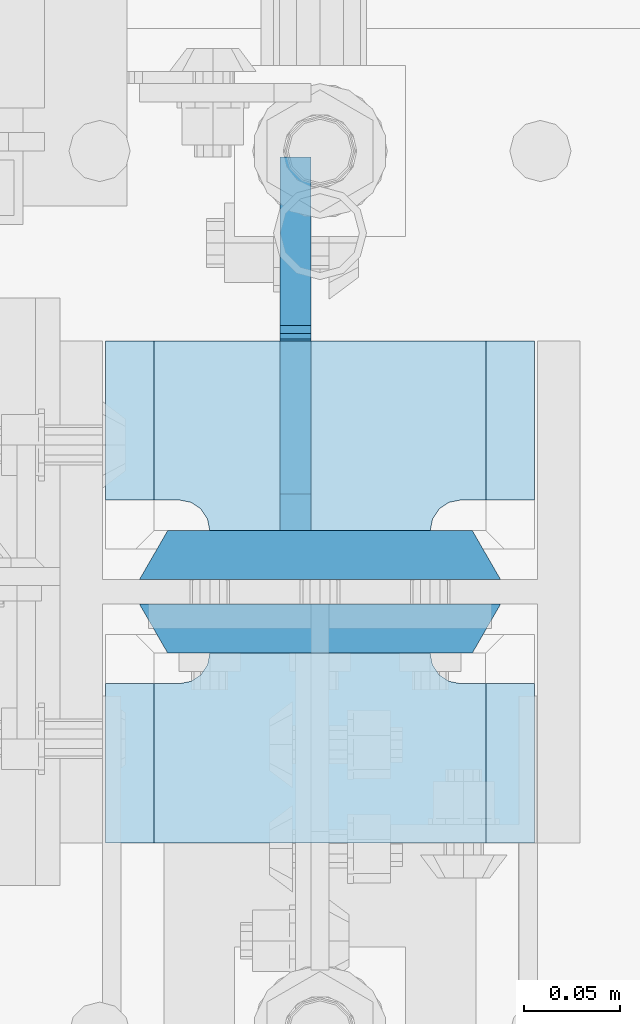
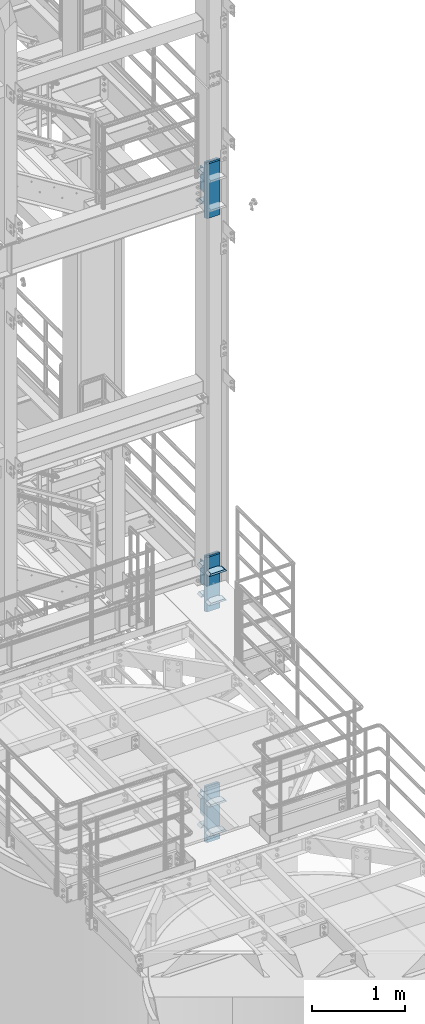
# One storey, part 1521 of 1876: 19 plates, 1 element without a shape of its own.
"""IFC2X3 building model written with IfcOpenShell, lengths in millimetres."""

from ifc_helpers import new_model, si_unit, frame, origin_with_axes, place, context, subcontext, project, spatial, faceted_brep, material, type_object, element, aggregate, save


model = new_model("IFC2X3")

# Units and contexts
model_context = context("Model", 3, precision=1e-05, world=origin_with_axes())
body_context = subcontext(model_context, "Body", "Model", "MODEL_VIEW")
ifc_project = project(units=[si_unit("LENGTHUNIT", "METRE", prefix="MILLI"), si_unit("AREAUNIT", "SQUARE_METRE"), si_unit("VOLUMEUNIT", "CUBIC_METRE"), si_unit("MASSUNIT", "GRAM", prefix="KILO"), si_unit("TIMEUNIT", "SECOND"), si_unit("PLANEANGLEUNIT", "RADIAN"), si_unit("SOLIDANGLEUNIT", "STERADIAN"), si_unit("THERMODYNAMICTEMPERATUREUNIT", "DEGREE_CELSIUS"), si_unit("LUMINOUSINTENSITYUNIT", "LUMEN")], contexts=[model_context])

# Site, building, storey
site_placement = place(None, origin_with_axes())
site = spatial("IfcSite", under=ifc_project, at=site_placement, CompositionType="ELEMENT")
building_placement = place(site_placement, origin_with_axes())
building = spatial("IfcBuilding", under=site, at=building_placement, Name="Undefined", CompositionType="ELEMENT")
storey_placement = place(building_placement, origin_with_axes())
storey = spatial("IfcBuildingStorey", under=building, at=storey_placement, Name="Undefined", CompositionType="ELEMENT", Elevation=0.0)

# Assembly, plates
assembly_placement = place(storey_placement, origin_with_axes())
assembly = element("IfcElementAssembly", 1, at=assembly_placement, inside=storey, Name="COLUMN", AssemblyPlace="NOTDEFINED", PredefinedType="RIGID_FRAME")
ifc_material_1 = material(Name="STEEL/A572-GR.50")
plate_type_1 = type_object("IfcPlateType", PredefinedType="NOTDEFINED")
plate_1_placement = place(assembly_placement, frame((7731.125, -6981.825, 12912.725012207), z_axis=(-1.0, 0.0, 0.0), x_axis=(0.0, -1.0, 0.0)))
plate_1 = element("IfcPlate", 2, at=plate_1_placement, type_object=plate_type_1, material=ifc_material_1, Name="PLATE", context=body_context, shape_type="Brep", body=[
    faceted_brep([(82.5500030517578, -12.7000000000007, 222.25), (82.5500030517578, 12.7000000000007, 197.150000002177), (0.0, 12.7000000000007, 197.150000002177), (0.0, -12.7000000000007, 222.25), (82.5500030517578, 12.7000000000007, 25.0999999978233), (82.5500030517578, -12.7000000000007, 0.0), (0.0, -12.6999999999998, 0.0), (0.0, 12.7000000000007, 25.0999999978233), (82.5500030517578, 12.7000000000007, 38.0999984741211), (82.5500030517578, -12.7000000000007, 38.0999984741211), (83.7584154731412, -12.7000000000007, 44.1750979629169), (83.7584154731412, 12.7000000000007, 44.1750979629169), (87.1996829004211, -12.7000000000007, 49.3253186254576), (87.1996829004211, 12.7000000000007, 49.3253186254576), (92.349903562962, -12.7000000000007, 52.7665860527377), (92.349903562962, 12.7000000000007, 52.7665860527377), (98.4250030517578, -12.7000000000007, 53.9749984741211), (98.4250030517578, 12.7000000000007, 53.9749984741211), (98.4250030517578, -12.7000000000007, 168.275001525879), (98.4250030517578, 12.7000000000007, 168.275001525879), (92.349903562962, -12.7000000000007, 169.483413947262), (92.349903562962, 12.7000000000007, 169.483413947262), (87.1996829004211, -12.7000000000007, 172.924681374543), (87.1996829004211, 12.7000000000007, 172.924681374543), (83.7584154731412, -12.7000000000007, 178.074902037083), (83.7584154731412, 12.7000000000007, 178.074902037083), (82.5500030517578, -12.7000000000007, 184.150001525879), (82.5500030517578, 12.7000000000007, 184.150001525879)], [[[0, 1, 2, 3]], [[4, 5, 6, 7]], [[8, 9, 5, 4]], [[10, 9, 8, 11]], [[12, 10, 11, 13]], [[14, 12, 13, 15]], [[16, 14, 15, 17]], [[18, 16, 17, 19]], [[20, 18, 19, 21]], [[22, 20, 21, 23]], [[24, 22, 23, 25]], [[26, 24, 25, 27]], [[6, 5, 9, 10, 12, 14, 16, 18, 20, 22, 24, 26, 0, 3]], [[7, 6, 3, 2]], [[27, 25, 23, 21, 19, 17, 15, 13, 11, 8, 4, 7, 2, 1]], [[26, 27, 1, 0]]]),
])
plate_2_placement = place(assembly_placement, frame((7731.125, -6981.825, 13296.9), z_axis=(-1.0, 0.0, 0.0), x_axis=(0.0, -1.0, 0.0)))
plate_2 = element("IfcPlate", 3, at=plate_2_placement, type_object=plate_type_1, material=ifc_material_1, Name="PLATE", context=body_context, shape_type="Brep", body=[
    faceted_brep([(82.5500030517578, -12.7000000000007, 222.25), (82.5500030517578, 12.7000000000007, 197.150000002177), (0.0, 12.7000000000007, 197.150000002177), (0.0, -12.7000000000007, 222.25), (82.5500030517578, 12.7000000000007, 25.0999999978233), (82.5500030517578, -12.7000000000007, 0.0), (0.0, -12.6999999999998, 0.0), (0.0, 12.7000000000007, 25.0999999978233), (82.5500030517578, 12.7000000000007, 38.0999984741211), (82.5500030517578, -12.7000000000007, 38.0999984741211), (83.7584154731412, -12.7000000000007, 44.1750979629169), (83.7584154731412, 12.7000000000007, 44.1750979629169), (87.1996829004211, -12.7000000000007, 49.3253186254576), (87.1996829004211, 12.7000000000007, 49.3253186254576), (92.349903562962, -12.7000000000007, 52.7665860527377), (92.349903562962, 12.7000000000007, 52.7665860527377), (98.4250030517578, -12.7000000000007, 53.9749984741211), (98.4250030517578, 12.7000000000007, 53.9749984741211), (98.4250030517578, -12.7000000000007, 168.275001525879), (98.4250030517578, 12.7000000000007, 168.275001525879), (92.349903562962, -12.7000000000007, 169.483413947262), (92.349903562962, 12.7000000000007, 169.483413947262), (87.1996829004211, -12.7000000000007, 172.924681374543), (87.1996829004211, 12.7000000000007, 172.924681374543), (83.7584154731412, -12.7000000000007, 178.074902037083), (83.7584154731412, 12.7000000000007, 178.074902037083), (82.5500030517578, -12.7000000000007, 184.150001525879), (82.5500030517578, 12.7000000000007, 184.150001525879)], [[[0, 1, 2, 3]], [[4, 5, 6, 7]], [[8, 9, 5, 4]], [[10, 9, 8, 11]], [[12, 10, 11, 13]], [[14, 12, 13, 15]], [[16, 14, 15, 17]], [[18, 16, 17, 19]], [[20, 18, 19, 21]], [[22, 20, 21, 23]], [[24, 22, 23, 25]], [[26, 24, 25, 27]], [[6, 5, 9, 10, 12, 14, 16, 18, 20, 22, 24, 26, 0, 3]], [[7, 6, 3, 2]], [[27, 25, 23, 21, 19, 17, 15, 13, 11, 8, 4, 7, 2, 1]], [[26, 27, 1, 0]]]),
])
plate_3_placement = place(assembly_placement, frame((7731.125, -7143.75, 7756.52500610352), z_axis=(-1.0, 0.0, 0.0), x_axis=(0.0, -1.0, 0.0)))
plate_3 = element("IfcPlate", 4, at=plate_3_placement, type_object=plate_type_1, material=ifc_material_1, Name="PLATE", context=body_context, shape_type="Brep", body=[
    faceted_brep([(98.4250030517578, -12.7000000000007, 222.25), (98.4250030517578, 12.7000000000007, 197.150000002177), (15.875, 12.7000000000007, 197.150000002177), (15.875, -12.7000000000007, 222.25), (14.6665875786157, -12.7000000000007, 178.074902037082), (15.875, -12.7000000000007, 184.150001525879), (15.875, 12.7000000000007, 184.150001525879), (14.6665875786157, 12.7000000000007, 178.074902037082), (11.2253201513358, -12.7000000000007, 172.924681374541), (11.2253201513358, 12.7000000000007, 172.924681374541), (6.07509948879488, -12.7000000000007, 169.483413947261), (6.07509948879488, 12.7000000000007, 169.483413947261), (0.0, -12.7000000000007, 168.275001525879), (0.0, 12.7000000000007, 168.275001525879), (0.0, -12.7000000000007, 53.9749984741211), (0.0, 12.7000000000007, 53.9749984741211), (6.07509948879579, -12.7000000000007, 52.7665860527377), (6.07509948879579, 12.7000000000007, 52.7665860527377), (11.2253201513367, -12.7000000000007, 49.3253186254576), (11.2253201513367, 12.7000000000007, 49.3253186254576), (14.6665875786166, -12.7000000000007, 44.1750979629169), (14.6665875786166, 12.7000000000007, 44.1750979629169), (15.875, -12.7000000000007, 38.0999984741211), (15.875, 12.7000000000007, 38.0999984741211), (15.875, 12.7000000000007, 25.0999999978233), (15.875, -12.7000000000007, 0.0), (98.4250030517578, 12.7000000000007, 25.0999999978233), (98.4250030517578, -12.7000000000007, 0.0)], [[[0, 1, 2, 3]], [[4, 5, 6, 7]], [[8, 4, 7, 9]], [[10, 8, 9, 11]], [[12, 10, 11, 13]], [[14, 12, 13, 15]], [[16, 14, 15, 17]], [[18, 16, 17, 19]], [[20, 18, 19, 21]], [[22, 20, 21, 23]], [[22, 23, 24, 25]], [[26, 27, 25, 24]], [[5, 4, 8, 10, 12, 14, 16, 18, 20, 22, 25, 27, 0, 3]], [[6, 5, 3, 2]], [[26, 24, 23, 21, 19, 17, 15, 13, 11, 9, 7, 6, 2, 1]], [[27, 26, 1, 0]]]),
])
plate_4_placement = place(assembly_placement, frame((7731.125, -7143.75, 8140.7), z_axis=(-1.0, 0.0, 0.0), x_axis=(0.0, -1.0, 0.0)))
plate_4 = element("IfcPlate", 5, at=plate_4_placement, type_object=plate_type_1, material=ifc_material_1, Name="PLATE", context=body_context, shape_type="Brep", body=[
    faceted_brep([(98.4250030517578, -12.7000000000007, 222.25), (98.4250030517578, 12.7000000000007, 197.150000002177), (15.875, 12.7000000000007, 197.150000002177), (15.875, -12.7000000000007, 222.25), (14.6665875786157, -12.7000000000007, 178.074902037082), (15.875, -12.7000000000007, 184.150001525879), (15.875, 12.7000000000007, 184.150001525879), (14.6665875786157, 12.7000000000007, 178.074902037082), (11.2253201513358, -12.7000000000007, 172.924681374541), (11.2253201513358, 12.7000000000007, 172.924681374541), (6.07509948879488, -12.7000000000007, 169.483413947261), (6.07509948879488, 12.7000000000007, 169.483413947261), (0.0, -12.7000000000007, 168.275001525879), (0.0, 12.7000000000007, 168.275001525879), (0.0, -12.7000000000007, 53.9749984741211), (0.0, 12.7000000000007, 53.9749984741211), (6.07509948879579, -12.7000000000007, 52.7665860527377), (6.07509948879579, 12.7000000000007, 52.7665860527377), (11.2253201513367, -12.7000000000007, 49.3253186254576), (11.2253201513367, 12.7000000000007, 49.3253186254576), (14.6665875786166, -12.7000000000007, 44.1750979629169), (14.6665875786166, 12.7000000000007, 44.1750979629169), (15.875, -12.7000000000007, 38.0999984741211), (15.875, 12.7000000000007, 38.0999984741211), (15.875, 12.7000000000007, 25.0999999978233), (15.875, -12.7000000000007, 0.0), (98.4250030517578, 12.7000000000007, 25.0999999978233), (98.4250030517578, -12.7000000000007, 0.0)], [[[0, 1, 2, 3]], [[4, 5, 6, 7]], [[8, 4, 7, 9]], [[10, 8, 9, 11]], [[12, 10, 11, 13]], [[14, 12, 13, 15]], [[16, 14, 15, 17]], [[18, 16, 17, 19]], [[20, 18, 19, 21]], [[22, 20, 21, 23]], [[22, 23, 24, 25]], [[26, 27, 25, 24]], [[5, 4, 8, 10, 12, 14, 16, 18, 20, 22, 25, 27, 0, 3]], [[6, 5, 3, 2]], [[26, 24, 23, 21, 19, 17, 15, 13, 11, 9, 7, 6, 2, 1]], [[27, 26, 1, 0]]]),
])
plate_5_placement = place(assembly_placement, frame((7731.125, -6981.825, 7756.52500610352), z_axis=(-1.0, 0.0, 0.0), x_axis=(0.0, -1.0, 0.0)))
plate_5 = element("IfcPlate", 6, at=plate_5_placement, type_object=plate_type_1, material=ifc_material_1, Name="PLATE", context=body_context, shape_type="Brep", body=[
    faceted_brep([(82.5500030517578, -12.7000000000007, 222.25), (82.5500030517578, 12.7000000000007, 197.150000002177), (0.0, 12.7000000000007, 197.150000002177), (0.0, -12.7000000000007, 222.25), (82.5500030517578, 12.7000000000007, 25.0999999978233), (82.5500030517578, -12.7000000000007, 0.0), (0.0, -12.6999999999998, 0.0), (0.0, 12.7000000000007, 25.0999999978233), (82.5500030517578, 12.7000000000007, 38.0999984741211), (82.5500030517578, -12.7000000000007, 38.0999984741211), (83.7584154731412, -12.7000000000007, 44.1750979629169), (83.7584154731412, 12.7000000000007, 44.1750979629169), (87.1996829004211, -12.7000000000007, 49.3253186254576), (87.1996829004211, 12.7000000000007, 49.3253186254576), (92.349903562962, -12.7000000000007, 52.7665860527377), (92.349903562962, 12.7000000000007, 52.7665860527377), (98.4250030517578, -12.7000000000007, 53.9749984741211), (98.4250030517578, 12.7000000000007, 53.9749984741211), (98.4250030517578, -12.7000000000007, 168.275001525879), (98.4250030517578, 12.7000000000007, 168.275001525879), (92.349903562962, -12.7000000000007, 169.483413947262), (92.349903562962, 12.7000000000007, 169.483413947262), (87.1996829004211, -12.7000000000007, 172.924681374543), (87.1996829004211, 12.7000000000007, 172.924681374543), (83.7584154731412, -12.7000000000007, 178.074902037083), (83.7584154731412, 12.7000000000007, 178.074902037083), (82.5500030517578, -12.7000000000007, 184.150001525879), (82.5500030517578, 12.7000000000007, 184.150001525879)], [[[0, 1, 2, 3]], [[4, 5, 6, 7]], [[8, 9, 5, 4]], [[10, 9, 8, 11]], [[12, 10, 11, 13]], [[14, 12, 13, 15]], [[16, 14, 15, 17]], [[18, 16, 17, 19]], [[20, 18, 19, 21]], [[22, 20, 21, 23]], [[24, 22, 23, 25]], [[26, 24, 25, 27]], [[6, 5, 9, 10, 12, 14, 16, 18, 20, 22, 24, 26, 0, 3]], [[7, 6, 3, 2]], [[27, 25, 23, 21, 19, 17, 15, 13, 11, 8, 4, 7, 2, 1]], [[26, 27, 1, 0]]]),
])
plate_6_placement = place(assembly_placement, frame((7731.125, -6981.825, 8140.7), z_axis=(-1.0, 0.0, 0.0), x_axis=(0.0, -1.0, 0.0)))
plate_6 = element("IfcPlate", 7, at=plate_6_placement, type_object=plate_type_1, material=ifc_material_1, Name="PLATE", context=body_context, shape_type="Brep", body=[
    faceted_brep([(82.5500030517578, -12.7000000000007, 222.25), (82.5500030517578, 12.7000000000007, 197.150000002177), (0.0, 12.7000000000007, 197.150000002177), (0.0, -12.7000000000007, 222.25), (82.5500030517578, 12.7000000000007, 25.0999999978233), (82.5500030517578, -12.7000000000007, 0.0), (0.0, -12.6999999999998, 0.0), (0.0, 12.7000000000007, 25.0999999978233), (82.5500030517578, 12.7000000000007, 38.0999984741211), (82.5500030517578, -12.7000000000007, 38.0999984741211), (83.7584154731412, -12.7000000000007, 44.1750979629169), (83.7584154731412, 12.7000000000007, 44.1750979629169), (87.1996829004211, -12.7000000000007, 49.3253186254576), (87.1996829004211, 12.7000000000007, 49.3253186254576), (92.349903562962, -12.7000000000007, 52.7665860527377), (92.349903562962, 12.7000000000007, 52.7665860527377), (98.4250030517578, -12.7000000000007, 53.9749984741211), (98.4250030517578, 12.7000000000007, 53.9749984741211), (98.4250030517578, -12.7000000000007, 168.275001525879), (98.4250030517578, 12.7000000000007, 168.275001525879), (92.349903562962, -12.7000000000007, 169.483413947262), (92.349903562962, 12.7000000000007, 169.483413947262), (87.1996829004211, -12.7000000000007, 172.924681374543), (87.1996829004211, 12.7000000000007, 172.924681374543), (83.7584154731412, -12.7000000000007, 178.074902037083), (83.7584154731412, 12.7000000000007, 178.074902037083), (82.5500030517578, -12.7000000000007, 184.150001525879), (82.5500030517578, 12.7000000000007, 184.150001525879)], [[[0, 1, 2, 3]], [[4, 5, 6, 7]], [[8, 9, 5, 4]], [[10, 9, 8, 11]], [[12, 10, 11, 13]], [[14, 12, 13, 15]], [[16, 14, 15, 17]], [[18, 16, 17, 19]], [[20, 18, 19, 21]], [[22, 20, 21, 23]], [[24, 22, 23, 25]], [[26, 24, 25, 27]], [[6, 5, 9, 10, 12, 14, 16, 18, 20, 22, 24, 26, 0, 3]], [[7, 6, 3, 2]], [[27, 25, 23, 21, 19, 17, 15, 13, 11, 8, 4, 7, 2, 1]], [[26, 27, 1, 0]]]),
])
ifc_material_2 = material(Name="STEEL/A572-50")
plate_7_placement = place(assembly_placement, frame((7731.125, -7143.75, 4733.92501220703), z_axis=(-1.0, 0.0, 0.0), x_axis=(0.0, -1.0, 0.0)))
plate_7 = element("IfcPlate", 8, at=plate_7_placement, type_object=plate_type_1, material=ifc_material_2, Name="PLATE", context=body_context, shape_type="Brep", body=[
    faceted_brep([(98.4250030517578, -12.7000000000007, 222.25), (98.4250030517578, 12.7000000000007, 197.150000002177), (15.875, 12.7000000000007, 197.150000002177), (15.875, -12.7000000000007, 222.25), (14.6665875786157, -12.7000000000007, 178.074902037082), (15.875, -12.7000000000007, 184.150001525879), (15.875, 12.7000000000007, 184.150001525879), (14.6665875786157, 12.7000000000007, 178.074902037082), (11.2253201513358, -12.7000000000007, 172.924681374541), (11.2253201513358, 12.7000000000007, 172.924681374541), (6.07509948879488, -12.7000000000007, 169.483413947261), (6.07509948879488, 12.7000000000007, 169.483413947261), (0.0, -12.7000000000007, 168.275001525879), (0.0, 12.7000000000007, 168.275001525879), (0.0, -12.7000000000007, 53.9749984741211), (0.0, 12.7000000000007, 53.9749984741211), (6.07509948879579, -12.7000000000007, 52.7665860527377), (6.07509948879579, 12.7000000000007, 52.7665860527377), (11.2253201513367, -12.7000000000007, 49.3253186254576), (11.2253201513367, 12.7000000000007, 49.3253186254576), (14.6665875786166, -12.7000000000007, 44.1750979629169), (14.6665875786166, 12.7000000000007, 44.1750979629169), (15.875, -12.7000000000007, 38.0999984741211), (15.875, 12.7000000000007, 38.0999984741211), (15.875, 12.7000000000007, 25.0999999978233), (15.875, -12.7000000000007, 0.0), (98.4250030517578, 12.7000000000007, 25.0999999978233), (98.4250030517578, -12.7000000000007, 0.0)], [[[0, 1, 2, 3]], [[4, 5, 6, 7]], [[8, 4, 7, 9]], [[10, 8, 9, 11]], [[12, 10, 11, 13]], [[14, 12, 13, 15]], [[16, 14, 15, 17]], [[18, 16, 17, 19]], [[20, 18, 19, 21]], [[22, 20, 21, 23]], [[22, 23, 24, 25]], [[26, 27, 25, 24]], [[5, 4, 8, 10, 12, 14, 16, 18, 20, 22, 25, 27, 0, 3]], [[6, 5, 3, 2]], [[26, 24, 23, 21, 19, 17, 15, 13, 11, 9, 7, 6, 2, 1]], [[27, 26, 1, 0]]]),
])
plate_8_placement = place(assembly_placement, frame((7731.125, -7143.75, 5118.1), z_axis=(-1.0, 0.0, 0.0), x_axis=(0.0, -1.0, 0.0)))
plate_8 = element("IfcPlate", 9, at=plate_8_placement, type_object=plate_type_1, material=ifc_material_2, Name="PLATE", context=body_context, shape_type="Brep", body=[
    faceted_brep([(98.4250030517578, -12.7000000000007, 222.25), (98.4250030517578, 12.7000000000007, 197.150000002177), (15.875, 12.7000000000007, 197.150000002177), (15.875, -12.7000000000007, 222.25), (14.6665875786157, -12.7000000000007, 178.074902037082), (15.875, -12.7000000000007, 184.150001525879), (15.875, 12.7000000000007, 184.150001525879), (14.6665875786157, 12.7000000000007, 178.074902037082), (11.2253201513358, -12.7000000000007, 172.924681374541), (11.2253201513358, 12.7000000000007, 172.924681374541), (6.07509948879488, -12.7000000000007, 169.483413947261), (6.07509948879488, 12.7000000000007, 169.483413947261), (0.0, -12.7000000000007, 168.275001525879), (0.0, 12.7000000000007, 168.275001525879), (0.0, -12.7000000000007, 53.9749984741211), (0.0, 12.7000000000007, 53.9749984741211), (6.07509948879579, -12.7000000000007, 52.7665860527377), (6.07509948879579, 12.7000000000007, 52.7665860527377), (11.2253201513367, -12.7000000000007, 49.3253186254576), (11.2253201513367, 12.7000000000007, 49.3253186254576), (14.6665875786166, -12.7000000000007, 44.1750979629169), (14.6665875786166, 12.7000000000007, 44.1750979629169), (15.875, -12.7000000000007, 38.0999984741211), (15.875, 12.7000000000007, 38.0999984741211), (15.875, 12.7000000000007, 25.0999999978233), (15.875, -12.7000000000007, 0.0), (98.4250030517578, 12.7000000000007, 25.0999999978233), (98.4250030517578, -12.7000000000007, 0.0)], [[[0, 1, 2, 3]], [[4, 5, 6, 7]], [[8, 4, 7, 9]], [[10, 8, 9, 11]], [[12, 10, 11, 13]], [[14, 12, 13, 15]], [[16, 14, 15, 17]], [[18, 16, 17, 19]], [[20, 18, 19, 21]], [[22, 20, 21, 23]], [[22, 23, 24, 25]], [[26, 27, 25, 24]], [[5, 4, 8, 10, 12, 14, 16, 18, 20, 22, 25, 27, 0, 3]], [[6, 5, 3, 2]], [[26, 24, 23, 21, 19, 17, 15, 13, 11, 9, 7, 6, 2, 1]], [[27, 26, 1, 0]]]),
])
plate_9_placement = place(assembly_placement, frame((7731.125, -6981.825, 4733.92501220703), z_axis=(-1.0, 0.0, 0.0), x_axis=(0.0, -1.0, 0.0)))
plate_9 = element("IfcPlate", 10, at=plate_9_placement, type_object=plate_type_1, material=ifc_material_2, Name="PLATE", context=body_context, shape_type="Brep", body=[
    faceted_brep([(82.5500030517578, -12.7000000000007, 222.25), (82.5500030517578, 12.7000000000007, 197.150000002177), (0.0, 12.7000000000007, 197.150000002177), (0.0, -12.7000000000007, 222.25), (82.5500030517578, 12.7000000000007, 25.0999999978233), (82.5500030517578, -12.7000000000007, 0.0), (0.0, -12.6999999999998, 0.0), (0.0, 12.7000000000007, 25.0999999978233), (82.5500030517578, 12.7000000000007, 38.0999984741211), (82.5500030517578, -12.7000000000007, 38.0999984741211), (83.7584154731412, -12.7000000000007, 44.1750979629169), (83.7584154731412, 12.7000000000007, 44.1750979629169), (87.1996829004211, -12.7000000000007, 49.3253186254576), (87.1996829004211, 12.7000000000007, 49.3253186254576), (92.349903562962, -12.7000000000007, 52.7665860527377), (92.349903562962, 12.7000000000007, 52.7665860527377), (98.4250030517578, -12.7000000000007, 53.9749984741211), (98.4250030517578, 12.7000000000007, 53.9749984741211), (98.4250030517578, -12.7000000000007, 168.275001525879), (98.4250030517578, 12.7000000000007, 168.275001525879), (92.349903562962, -12.7000000000007, 169.483413947262), (92.349903562962, 12.7000000000007, 169.483413947262), (87.1996829004211, -12.7000000000007, 172.924681374543), (87.1996829004211, 12.7000000000007, 172.924681374543), (83.7584154731412, -12.7000000000007, 178.074902037083), (83.7584154731412, 12.7000000000007, 178.074902037083), (82.5500030517578, -12.7000000000007, 184.150001525879), (82.5500030517578, 12.7000000000007, 184.150001525879)], [[[0, 1, 2, 3]], [[4, 5, 6, 7]], [[8, 9, 5, 4]], [[10, 9, 8, 11]], [[12, 10, 11, 13]], [[14, 12, 13, 15]], [[16, 14, 15, 17]], [[18, 16, 17, 19]], [[20, 18, 19, 21]], [[22, 20, 21, 23]], [[24, 22, 23, 25]], [[26, 24, 25, 27]], [[6, 5, 9, 10, 12, 14, 16, 18, 20, 22, 24, 26, 0, 3]], [[7, 6, 3, 2]], [[27, 25, 23, 21, 19, 17, 15, 13, 11, 8, 4, 7, 2, 1]], [[26, 27, 1, 0]]]),
])
plate_10_placement = place(assembly_placement, frame((7731.125, -6981.825, 5118.1), z_axis=(-1.0, 0.0, 0.0), x_axis=(0.0, -1.0, 0.0)))
plate_10 = element("IfcPlate", 11, at=plate_10_placement, type_object=plate_type_1, material=ifc_material_2, Name="PLATE", context=body_context, shape_type="Brep", body=[
    faceted_brep([(82.5500030517578, -12.7000000000007, 222.25), (82.5500030517578, 12.7000000000007, 197.150000002177), (0.0, 12.7000000000007, 197.150000002177), (0.0, -12.7000000000007, 222.25), (82.5500030517578, 12.7000000000007, 25.0999999978233), (82.5500030517578, -12.7000000000007, 0.0), (0.0, -12.6999999999998, 0.0), (0.0, 12.7000000000007, 25.0999999978233), (82.5500030517578, 12.7000000000007, 38.0999984741211), (82.5500030517578, -12.7000000000007, 38.0999984741211), (83.7584154731412, -12.7000000000007, 44.1750979629169), (83.7584154731412, 12.7000000000007, 44.1750979629169), (87.1996829004211, -12.7000000000007, 49.3253186254576), (87.1996829004211, 12.7000000000007, 49.3253186254576), (92.349903562962, -12.7000000000007, 52.7665860527377), (92.349903562962, 12.7000000000007, 52.7665860527377), (98.4250030517578, -12.7000000000007, 53.9749984741211), (98.4250030517578, 12.7000000000007, 53.9749984741211), (98.4250030517578, -12.7000000000007, 168.275001525879), (98.4250030517578, 12.7000000000007, 168.275001525879), (92.349903562962, -12.7000000000007, 169.483413947262), (92.349903562962, 12.7000000000007, 169.483413947262), (87.1996829004211, -12.7000000000007, 172.924681374543), (87.1996829004211, 12.7000000000007, 172.924681374543), (83.7584154731412, -12.7000000000007, 178.074902037083), (83.7584154731412, 12.7000000000007, 178.074902037083), (82.5500030517578, -12.7000000000007, 184.150001525879), (82.5500030517578, 12.7000000000007, 184.150001525879)], [[[0, 1, 2, 3]], [[4, 5, 6, 7]], [[8, 9, 5, 4]], [[10, 9, 8, 11]], [[12, 10, 11, 13]], [[14, 12, 13, 15]], [[16, 14, 15, 17]], [[18, 16, 17, 19]], [[20, 18, 19, 21]], [[22, 20, 21, 23]], [[24, 22, 23, 25]], [[26, 24, 25, 27]], [[6, 5, 9, 10, 12, 14, 16, 18, 20, 22, 24, 26, 0, 3]], [[7, 6, 3, 2]], [[27, 25, 23, 21, 19, 17, 15, 13, 11, 8, 4, 7, 2, 1]], [[26, 27, 1, 0]]]),
])
plate_type_2 = type_object("IfcPlateType", PredefinedType="NOTDEFINED")
plate_11_placement = place(assembly_placement, frame((7526.3375, -7131.05, 13462.0), z_axis=(1.0, 0.0, 0.0), x_axis=(0.0, 0.0, -1.0)))
plate_11 = element("IfcPlate", 12, at=plate_11_placement, type_object=plate_type_2, material=ifc_material_1, Name="PLATE", context=body_context, shape_type="Brep", body=[
    faceted_brep([(0.0, -12.6999999999998, 172.660303166218), (714.375, -12.6999999999998, 172.660303166232), (714.375, 12.6999999999998, 187.324996948242), (0.0, 12.6999999999998, 187.324996948242), (714.375, -12.6999999999998, 14.6646968337647), (714.375, 12.6999999999998, 0.0), (0.0, 12.6999999999998, 0.0), (0.0, -12.6999999999998, 14.6646968337648)], [[[0, 1, 2, 3]], [[2, 1, 4, 5]], [[3, 2, 5, 6]], [[0, 3, 6, 7]], [[1, 0, 7, 4]], [[6, 5, 4, 7]]]),
])
plate_12_placement = place(assembly_placement, frame((7526.3375, -7092.95, 13462.0), z_axis=(1.0, 0.0, 0.0), x_axis=(0.0, 0.0, -1.0)))
plate_12 = element("IfcPlate", 13, at=plate_12_placement, type_object=plate_type_2, material=ifc_material_1, Name="PLATE", context=body_context, shape_type="Brep", body=[
    faceted_brep([(0.0, 12.6999999999998, 172.66030316161), (0.0, -12.6999999999998, 187.324996948242), (714.375, -12.6999999999998, 187.324996948242), (714.375, 12.6999999999998, 172.660303161603), (714.375, 12.6999999999998, 14.6646968384017), (0.0, 12.6999999999998, 14.6646968383725), (0.0, -12.6999999999998, 0.0), (714.375, -12.6999999999998, 0.0)], [[[0, 1, 2, 3]], [[0, 3, 4, 5]], [[1, 0, 5, 6]], [[2, 1, 6, 7]], [[3, 2, 7, 4]], [[6, 5, 4, 7]]]),
])
plate_13_placement = place(assembly_placement, frame((7526.3375, -7131.05, 8305.8), z_axis=(1.0, 0.0, 0.0), x_axis=(0.0, 0.0, -1.0)))
plate_13 = element("IfcPlate", 14, at=plate_13_placement, type_object=plate_type_2, material=ifc_material_1, Name="PLATE", context=body_context, shape_type="Brep", body=[
    faceted_brep([(0.0, -12.6999999999998, 172.660303166218), (714.375, -12.6999999999998, 172.660303166232), (714.375, 12.6999999999998, 187.324996948242), (0.0, 12.6999999999998, 187.324996948242), (714.375, -12.6999999999998, 14.6646968337647), (714.375, 12.6999999999998, 0.0), (0.0, 12.6999999999998, 0.0), (0.0, -12.6999999999998, 14.6646968337648)], [[[0, 1, 2, 3]], [[2, 1, 4, 5]], [[3, 2, 5, 6]], [[0, 3, 6, 7]], [[1, 0, 7, 4]], [[6, 5, 4, 7]]]),
])
plate_14_placement = place(assembly_placement, frame((7526.3375, -7092.95, 8305.8), z_axis=(1.0, 0.0, 0.0), x_axis=(0.0, 0.0, -1.0)))
plate_14 = element("IfcPlate", 15, at=plate_14_placement, type_object=plate_type_2, material=ifc_material_1, Name="PLATE", context=body_context, shape_type="Brep", body=[
    faceted_brep([(0.0, 12.6999999999998, 172.66030316161), (0.0, -12.6999999999998, 187.324996948242), (714.375, -12.6999999999998, 187.324996948242), (714.375, 12.6999999999998, 172.660303161603), (714.375, 12.6999999999998, 14.6646968384017), (0.0, 12.6999999999998, 14.6646968383725), (0.0, -12.6999999999998, 0.0), (714.375, -12.6999999999998, 0.0)], [[[0, 1, 2, 3]], [[0, 3, 4, 5]], [[1, 0, 5, 6]], [[2, 1, 6, 7]], [[3, 2, 7, 4]], [[6, 5, 4, 7]]]),
])
plate_15_placement = place(assembly_placement, frame((7526.3375, -7131.05, 5283.2), z_axis=(1.0, 0.0, 0.0), x_axis=(0.0, 0.0, -1.0)))
plate_15 = element("IfcPlate", 16, at=plate_15_placement, type_object=plate_type_2, material=ifc_material_1, Name="PLATE", context=body_context, shape_type="Brep", body=[
    faceted_brep([(0.0, -12.6999999999998, 172.660303166218), (714.375, -12.6999999999998, 172.660303166232), (714.375, 12.6999999999998, 187.324996948242), (0.0, 12.6999999999998, 187.324996948242), (714.375, -12.6999999999998, 14.6646968337647), (714.375, 12.6999999999998, 0.0), (0.0, 12.6999999999998, 0.0), (0.0, -12.6999999999998, 14.6646968337648)], [[[0, 1, 2, 3]], [[2, 1, 4, 5]], [[3, 2, 5, 6]], [[0, 3, 6, 7]], [[1, 0, 7, 4]], [[6, 5, 4, 7]]]),
])
plate_16_placement = place(assembly_placement, frame((7526.3375, -7092.95, 5283.2), z_axis=(1.0, 0.0, 0.0), x_axis=(0.0, 0.0, -1.0)))
plate_16 = element("IfcPlate", 17, at=plate_16_placement, type_object=plate_type_2, material=ifc_material_1, Name="PLATE", context=body_context, shape_type="Brep", body=[
    faceted_brep([(0.0, 12.6999999999998, 172.66030316161), (0.0, -12.6999999999998, 187.324996948242), (714.375, -12.6999999999998, 187.324996948242), (714.375, 12.6999999999998, 172.660303161603), (714.375, 12.6999999999998, 14.6646968384017), (0.0, 12.6999999999998, 14.6646968383725), (0.0, -12.6999999999998, 0.0), (714.375, -12.6999999999998, 0.0)], [[[0, 1, 2, 3]], [[0, 3, 4, 5]], [[1, 0, 5, 6]], [[2, 1, 6, 7]], [[3, 2, 7, 4]], [[6, 5, 4, 7]]]),
])
plate_type_3 = type_object("IfcPlateType", PredefinedType="NOTDEFINED")
plate_17_placement = place(assembly_placement, frame((7607.3, -7080.25, 13284.2), z_axis=(0.0, 1.0, 0.0), x_axis=(0.0, 0.0, -1.0)))
plate_17 = element("IfcPlate", 18, at=plate_17_placement, type_object=plate_type_3, material=ifc_material_2, Name="PLATE", context=body_context, shape_type="Brep", body=[
    faceted_brep([(317.499526107607, -7.9375, 193.675002687783), (317.499987728603, -7.9375, 111.124768999664), (317.499987728603, 7.9375, 111.124768999664), (317.499526107607, 7.9375, 193.675003051758), (318.466744828744, -7.9375, 106.264694887646), (318.466744828744, 7.9375, 106.264694887646), (321.21978176921, -7.9375, 102.144533814409), (321.21978176921, 7.9375, 102.144533814409), (325.339973632152, -7.9375, 99.3915429540011), (325.339973632152, 7.9375, 99.3915429540011), (330.200058556071, -7.9375, 98.4248402089934), (330.200058556071, 7.9375, 98.4248402089934), (358.774999999998, -7.9375, 98.4249999999993), (358.774993896484, 7.9375, 98.4249999999993), (12.7000000839216, -7.9375, 193.674999999999), (12.7000000839216, 7.9375, 193.675003051758), (12.7000000839216, 7.9375, 111.124999809264), (12.7000000839216, -7.9375, 111.124999809264), (11.7332701613341, 7.9375, 106.264920291219), (11.7332701613341, -7.9375, 106.264920291219), (8.98025626085655, 7.9375, 102.144743823065), (8.98025626085655, -7.9375, 102.144743823065), (4.86007979270289, 7.9375, 99.3917299225868), (4.86007979270289, -7.9375, 99.3917299225868), (0.0, 7.9375, 98.4249999999993), (0.0, -7.9375, 98.4249999999993), (0.0, 7.9375, 0.0), (0.0, -7.9375, 0.0), (358.774993896484, -7.9375, 0.0), (358.774993896484, 7.9375, 0.0)], [[[0, 1, 2, 3]], [[4, 5, 2, 1]], [[6, 7, 5, 4]], [[8, 9, 7, 6]], [[10, 11, 9, 8]], [[12, 13, 11, 10]], [[14, 15, 16, 17]], [[17, 16, 18, 19]], [[19, 18, 20, 21]], [[21, 20, 22, 23]], [[23, 22, 24, 25]], [[26, 27, 25, 24]], [[28, 27, 26, 29]], [[8, 6, 4, 1, 0, 14, 17, 19, 21, 23, 25, 27, 28, 12, 10]], [[15, 14, 0, 3]], [[29, 26, 24, 22, 20, 18, 16, 15, 3, 2, 5, 7, 9, 11, 13]], [[28, 29, 13, 12]]]),
])
plate_18_placement = place(assembly_placement, frame((7607.30049991608, -7080.25, 8128.0), z_axis=(0.0, 1.0, 0.0), x_axis=(0.0, 0.0, -1.0)))
plate_18 = element("IfcPlate", 19, at=plate_18_placement, type_object=plate_type_3, material=ifc_material_2, Name="PLATE", context=body_context, shape_type="Brep", body=[
    faceted_brep([(4.86007979270289, -7.9375, 99.3917299225868), (4.86007979270289, 7.9375, 99.3917299225868), (0.0, 7.9375, 98.4249999999993), (0.0, -7.9375, 98.4249999999993), (8.98025626085655, -7.9375, 102.144743823065), (8.98025626085655, 7.9375, 102.144743823065), (11.7332701613341, -7.9375, 106.264920291219), (11.7332701613341, 7.9375, 106.264920291219), (12.7000000839216, -7.9375, 111.124999809264), (12.7000000839216, 7.9375, 111.124999809264), (12.7000000839216, -7.9375, 193.674999999999), (12.7000000839216, 7.9375, 193.675003051758), (19.0499992370605, -7.9375, 0.0), (0.0, -7.9375, 19.0499992370605), (0.0, 7.9375, 19.0499992370605), (19.0499992370605, 7.9375, 0.0), (339.724994659424, -7.9375, 0.0), (339.724994659424, 7.9375, 0.0), (358.774993896484, -7.9375, 19.0499992370605), (358.774993896484, 7.9375, 19.0499992370605), (358.774993896484, 7.9375, 98.4277343749891), (358.774932861329, -7.9375, 98.4277343749891), (330.200057030166, 7.9375, 98.427574584286), (330.200057030166, -7.9375, 98.427574584286), (325.339972106242, 7.9375, 99.3942773292947), (325.339972106242, -7.9375, 99.3942773292947), (321.219780243298, 7.9375, 102.147268189703), (321.219780243298, -7.9375, 102.147268189703), (318.466743302837, 7.9375, 106.26742926294), (318.466743302837, -7.9375, 106.26742926294), (317.4999862027, 7.9375, 111.127503374956), (317.4999862027, -7.9375, 111.127503374956), (317.499526107607, -7.9375, 193.675002687783), (317.499526107607, 7.9375, 193.675003051758)], [[[0, 1, 2, 3]], [[4, 5, 1, 0]], [[6, 7, 5, 4]], [[8, 9, 7, 6]], [[10, 11, 9, 8]], [[12, 13, 14, 15]], [[16, 12, 15, 17]], [[18, 16, 17, 19]], [[18, 19, 20, 21]], [[21, 20, 22, 23]], [[23, 22, 24, 25]], [[25, 24, 26, 27]], [[27, 26, 28, 29]], [[29, 28, 30, 31]], [[32, 31, 30, 33]], [[6, 4, 0, 3, 13, 12, 16, 18, 21, 23, 25, 27, 29, 31, 32, 10, 8]], [[14, 13, 3, 2]], [[33, 30, 28, 26, 24, 22, 20, 19, 17, 15, 14, 2, 1, 5, 7, 9, 11]], [[11, 10, 32, 33]]]),
])
plate_19_placement = place(assembly_placement, frame((7607.30049991608, -7080.25, 5105.4), z_axis=(0.0, 1.0, 0.0), x_axis=(0.0, 0.0, -1.0)))
plate_19 = element("IfcPlate", 20, at=plate_19_placement, type_object=plate_type_3, material=ifc_material_2, Name="PLATE", context=body_context, shape_type="Brep", body=[
    faceted_brep([(317.499987030027, -7.9375, 193.675002687786), (317.499987030027, -7.9375, 111.124999809264), (317.499987030027, 7.9375, 111.124999809264), (317.499987030027, 7.9375, 193.675003051758), (318.466716952618, -7.9375, 106.264920291219), (318.466716952618, 7.9375, 106.264920291219), (321.219730853096, -7.9375, 102.144743823065), (321.219730853096, 7.9375, 102.144743823065), (325.339907321249, -7.9375, 99.3917299225868), (325.339907321249, 7.9375, 99.3917299225868), (330.199986839292, -7.9375, 98.4249999999993), (330.199986839292, 7.9375, 98.4249999999993), (358.774999999998, -7.9375, 98.4249999999993), (358.774993896484, 7.9375, 98.4249999999993), (12.7000000839216, -7.9375, 193.674999999999), (12.7000000839216, 7.9375, 193.675003051758), (12.7000000839216, 7.9375, 111.124999809264), (12.7000000839216, -7.9375, 111.124999809264), (11.7332701613341, 7.9375, 106.264920291219), (11.7332701613341, -7.9375, 106.264920291219), (8.98025626085655, 7.9375, 102.144743823065), (8.98025626085655, -7.9375, 102.144743823065), (4.86007979270289, 7.9375, 99.3917299225868), (4.86007979270289, -7.9375, 99.3917299225868), (0.0, 7.9375, 98.4249999999993), (0.0, -7.9375, 98.4249999999993), (0.0, 7.9375, 19.0499992370605), (0.0, -7.9375, 19.0499992370605), (19.0499992370605, -7.9375, 0.0), (19.0499992370605, 7.9375, 0.0), (339.724994659424, -7.9375, 0.0), (339.724994659424, 7.9375, 0.0), (358.774993896484, -7.9375, 19.0499992370605), (358.774993896484, 7.9375, 19.0499992370605)], [[[0, 1, 2, 3]], [[4, 5, 2, 1]], [[6, 7, 5, 4]], [[8, 9, 7, 6]], [[10, 11, 9, 8]], [[12, 13, 11, 10]], [[14, 15, 16, 17]], [[17, 16, 18, 19]], [[19, 18, 20, 21]], [[21, 20, 22, 23]], [[23, 22, 24, 25]], [[26, 27, 25, 24]], [[28, 27, 26, 29]], [[30, 28, 29, 31]], [[32, 30, 31, 33]], [[8, 6, 4, 1, 0, 14, 17, 19, 21, 23, 25, 27, 28, 30, 32, 12, 10]], [[15, 14, 0, 3]], [[33, 31, 29, 26, 24, 22, 20, 18, 16, 15, 3, 2, 5, 7, 9, 11, 13]], [[32, 33, 13, 12]]]),
])
aggregate(assembly, [plate_1, plate_2, plate_11, plate_12, plate_17, plate_3, plate_4, plate_5, plate_6, plate_13, plate_14, plate_18, plate_7, plate_8, plate_9, plate_10, plate_15, plate_16, plate_19])

save(model, "model.ifc")
